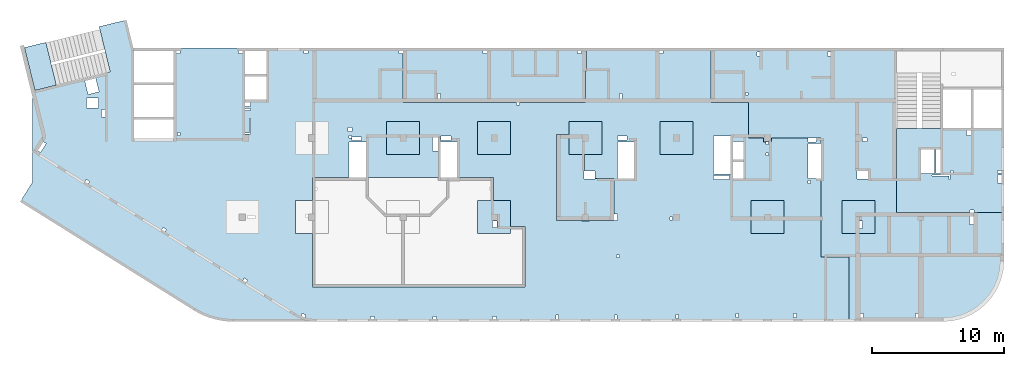
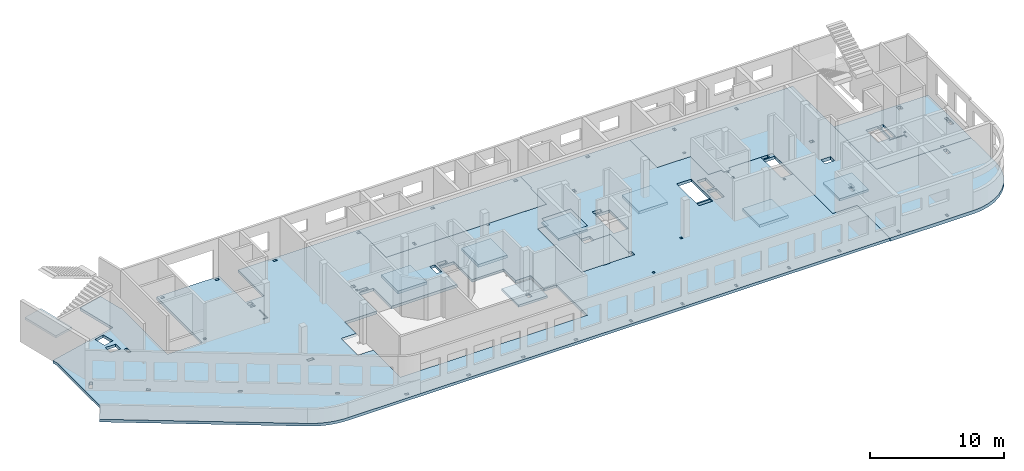
# One storey, part 2 of 10: 13 slabs.
"""IFC4 building model written with IfcOpenShell, lengths in millimetres."""

from ifc_helpers import new_model, entity, si_unit, converted_unit, derived_unit, direction, frame, origin, place, context, subcontext, project, spatial, indexed_curve, outline, extrude, material, type_object, element, save


model = new_model("IFC4")

# Units and contexts
model_context = context("Model", 3, precision=0.01, world=origin(), true_north=direction((6.12303176911189e-17, 1.0)))
plan_context = context("Plan", 3, precision=0.01, world=origin(), true_north=direction((6.12303176911189e-17, 1.0)))
body_context = subcontext(model_context, "Body", "Model", "MODEL_VIEW")
ifc_project = project(units=[si_unit("LENGTHUNIT", "METRE", prefix="MILLI"), si_unit("AREAUNIT", "SQUARE_METRE"), si_unit("VOLUMEUNIT", "CUBIC_METRE"), converted_unit("PLANEANGLEUNIT", "DEGREE", entity("IfcRatioMeasure", 0.0174532925199433), si_unit("PLANEANGLEUNIT", "RADIAN"), dimensions=[0, 0, 0, 0, 0, 0, 0]), si_unit("MASSUNIT", "GRAM", prefix="KILO"), derived_unit("MASSDENSITYUNIT", [(si_unit("MASSUNIT", "GRAM", prefix="KILO"), 1), (si_unit("LENGTHUNIT", "METRE"), -3)]), derived_unit("MOMENTOFINERTIAUNIT", [(si_unit("LENGTHUNIT", "METRE"), 4)]), si_unit("TIMEUNIT", "SECOND"), si_unit("FREQUENCYUNIT", "HERTZ"), si_unit("THERMODYNAMICTEMPERATUREUNIT", "DEGREE_CELSIUS"), derived_unit("THERMALTRANSMITTANCEUNIT", [(si_unit("MASSUNIT", "GRAM", prefix="KILO"), 1), (si_unit("THERMODYNAMICTEMPERATUREUNIT", "KELVIN"), -1), (si_unit("TIMEUNIT", "SECOND"), -3)]), derived_unit("VOLUMETRICFLOWRATEUNIT", [(si_unit("LENGTHUNIT", "METRE"), 3), (si_unit("TIMEUNIT", "SECOND"), -1)]), derived_unit("MASSFLOWRATEUNIT", [(si_unit("MASSUNIT", "GRAM", prefix="KILO"), 1), (si_unit("TIMEUNIT", "SECOND"), -1)]), derived_unit("ROTATIONALFREQUENCYUNIT", [(si_unit("TIMEUNIT", "SECOND"), -1)]), si_unit("ELECTRICCURRENTUNIT", "AMPERE"), si_unit("ELECTRICVOLTAGEUNIT", "VOLT"), si_unit("POWERUNIT", "WATT"), si_unit("FORCEUNIT", "NEWTON", prefix="KILO"), si_unit("ILLUMINANCEUNIT", "LUX"), si_unit("LUMINOUSFLUXUNIT", "LUMEN"), si_unit("LUMINOUSINTENSITYUNIT", "CANDELA"), derived_unit("USERDEFINED", [(si_unit("MASSUNIT", "GRAM", prefix="KILO"), -1), (si_unit("LENGTHUNIT", "METRE"), -2), (si_unit("TIMEUNIT", "SECOND"), 3), (si_unit("LUMINOUSFLUXUNIT", "LUMEN"), 1)]), derived_unit("LINEARVELOCITYUNIT", [(si_unit("LENGTHUNIT", "METRE"), 1), (si_unit("TIMEUNIT", "SECOND"), -1)]), si_unit("PRESSUREUNIT", "PASCAL"), derived_unit("USERDEFINED", [(si_unit("LENGTHUNIT", "METRE"), -2), (si_unit("MASSUNIT", "GRAM", prefix="KILO"), 1), (si_unit("TIMEUNIT", "SECOND"), -2)]), derived_unit("LINEARFORCEUNIT", [(si_unit("MASSUNIT", "GRAM", prefix="KILO"), 1), (si_unit("LENGTHUNIT", "METRE"), 1), (si_unit("TIMEUNIT", "SECOND"), -2), (si_unit("LENGTHUNIT", "METRE"), -1)]), derived_unit("PLANARFORCEUNIT", [(si_unit("MASSUNIT", "GRAM", prefix="KILO"), 1), (si_unit("LENGTHUNIT", "METRE"), 1), (si_unit("TIMEUNIT", "SECOND"), -2), (si_unit("LENGTHUNIT", "METRE"), -2)])], contexts=[model_context, plan_context])

# Site, building, storey
site_placement = place(None, origin())
site = spatial("IfcSite", under=ifc_project, at=site_placement, CompositionType="ELEMENT")
building_placement = place(site_placement, origin())
building = spatial("IfcBuilding", under=site, at=building_placement, CompositionType="ELEMENT")
storey_placement = place(building_placement, frame((0.0, 0.0, 4200.0)))
storey = spatial("IfcBuildingStorey", under=building, at=storey_placement, CompositionType="ELEMENT", Elevation=4200.0)

# Slabs
ifc_material = material()
slab_type_1 = type_object("IfcSlabType", PredefinedType="FLOOR", material=ifc_material)
slab_1_placement = place(storey_placement, origin())
element("IfcSlab", 1, at=slab_1_placement, inside=storey, type_object=slab_type_1, material=ifc_material, PredefinedType="FLOOR", context=body_context, shape_type="SweptSolid", body=[
    extrude(outline(indexed_curve([(-6148.863810471, 19959.387129888), (-6148.86381047096, 14559.387129888), (-2248.86381047095, 14559.387129888), (-2248.86381047095, 12934.387129888), (-6148.86381047096, 12934.387129888), (-6148.86381047092, 2589.38712988804), (-5948.86381047095, 2589.38712988804), (-5948.86381047095, 2889.3871298881), (-5748.86381047108, 2889.3871298881), (-5748.86381047108, 2589.38712988803), (-2048.86381047092, 2589.38712988804), (-2048.86381047089, -6010.61287011193), (-1848.86381047108, -6010.61287011193), (-1848.86381047108, -6210.61287011191), (-2048.86381047089, -6210.61287011191), (-2048.86381047088, -11210.612870112), (-4428.86381047078, -11210.612870112), (-4428.86381047078, -11310.612870112), (-6148.86381047087, -11310.612870112), (-6148.86381047084, -20730.6128701121), (-2048.86381047081, -20730.6128701119), (-2048.86381047066, -23560.6128701121), (651.136189529272, -23560.612870112), (651.136189529332, -24710.612870112), (951.136189529167, -24710.612870112), (951.136189529167, -24885.6128701119), (1151.13618952893, -24885.6128701119), (1151.13618952893, -25085.6128701119), (951.136189529167, -25085.6128701119), (951.136189529167, -25310.612870112), (651.13618952933, -25310.612870112), (651.136189529339, -28070.6128701119), (936.136189528923, -28070.6128701119), (936.136189528923, -28670.612870112), (651.136189529343, -28670.612870112), (651.136189529343, -29070.6128701119), (1056.13618952891, -29070.6128701119), (1056.13618952891, -28070.6128701119), (3726.13618952934, -28070.6128701119), (3726.13618952934, -29070.6128701119), (9651.13618952933, -29070.6128701119), (9651.13618952934, -31160.6128701119), (14551.1361895292, -31160.6128701119), (14551.1361895291, 15459.3871298881), (14542.4813688931, 15770.6090526414), (14516.5436590997, 16080.8689861379), (14473.4032338008, 16389.2079146363), (14413.1934403692, 16694.6727602364), (14336.1003877199, 16996.319328849), (14242.362371047, 17293.2152287074), (14132.2691352507, 17584.4427523971), (14006.1609793344, 17869.1017134961), (13864.4277045374, 18146.3122290575), (13707.5074094566, 18415.2174393349), (13700.2568944495, 18427.3871298935), (5483.13618952893, 31577.7857668567), (4013.36245521472, 30659.3871298881), (-2487.98081248951, 30659.387129888), (-2877.35012792884, 30754.3000199726), (-4338.56524356843, 24759.8315259752), (-7777.85952938926, 25598.1958951609), (-8282.29910745868, 23528.7900113196), (-6148.86381047102, 23008.7425863779), (-6148.86381047102, 22959.387129888), (701.136189528992, 22959.387129888), (701.136189529, 19959.387129888), (-6148.863810471, 19959.387129888)], self_intersect=False), holes=[indexed_curve([(5401.13618952907, 10739.3871298881), (6651.13618952907, 10739.3871298881), (7901.13618952907, 10739.3871298881), (7901.13618952906, 9439.38712988806), (11951.1361895291, 9439.38712988807), (11951.1361895292, -6635.6128701119), (7351.13618952919, -6635.61287011193), (7351.13618952918, -5560.61287011193), (6651.13618952918, -5560.61287011194), (5401.13618952913, -5560.61287011194), (5401.13618952912, -4310.61287011194), (5401.13618952912, -4260.61287011193), (3661.13618952913, -4260.61287011194), (3661.13618952912, -1510.61287011193), (951.13541588538, -1510.61287011193), (951.13541588538, -240.612870111946), (3661.13618952912, -240.612870111946), (3661.1361895291, 5409.38712988806), (951.13618952892, 5409.38712988806), (951.13618952892, 6669.38712988807), (3661.1361895291, 6669.38712988807), (3661.13618952909, 9439.38712988805), (5401.13618952906, 9439.38712988806), (5401.13618952907, 9489.38712988806), (5401.13618952907, 10739.3871298881)], self_intersect=False), indexed_curve([(401.136189529216, -9035.61287011196), (6651.1361895292, -9035.61287011194), (6901.1361895292, -9035.61287011194), (6901.1361895292, -10910.6128701119), (6951.1361895292, -10910.6128701119), (6951.1361895292, -11210.612870112), (6951.1361895292, -11510.612870112), (6901.1361895292, -11510.612870112), (6901.13618952895, -13385.612870112), (6901.13618952892, -13635.6128701119), (6401.13618952891, -13635.6128701119), (6401.13618952891, -13385.612870112), (3726.13618952915, -13385.612870112), (3726.13618952916, -11925.6128701119), (3166.13618952922, -11925.6128701119), (3166.13618952922, -11160.612870112), (1901.13618952915, -11160.612870112), (1901.13618952915, -12460.6128701119), (-598.863810470838, -12460.6128701119), (-598.863810470847, -9960.61287011195), (401.136189529218, -9960.61287011195), (401.136189529216, -9035.61287011196)], self_intersect=False), indexed_curve([(-2358.86381047109, 25649.3871298881), (-2358.86381047109, 26549.3871298881), (-1618.86381047108, 26549.3871298881), (-1618.86381047108, 25649.3871298881), (-2358.86381047109, 25649.3871298881)], self_intersect=False), indexed_curve([(-2845.01874476109, 25608.8640213711), (-3865.14975025251, 25857.5257884124), (-3663.85616990531, 26683.347133808), (-2643.72394620801, 26434.6903645437), (-2845.01874476109, 25608.8640213711)], self_intersect=False), indexed_curve([(1070.04881669485, 29610.0494864465), (937.569000669967, 29822.0615105065), (1616.01119569202, 30245.9909716361), (1748.48729366069, 30033.9848977099), (1070.04881669485, 29610.0494864465)], self_intersect=False), indexed_curve([(4124.42832046992, 26420.8069499175), (3954.6315026398, 26314.7081930707), (3795.65795471008, 26569.1240162138), (3965.4547725402, 26675.2227730606), (4124.42832046992, 26420.8069499175)], self_intersect=False), indexed_curve([(7754.32433139231, 20611.6456550412), (7584.52751356219, 20505.5468981944), (7425.55396563247, 20759.9627213374), (7595.35078346259, 20866.0614781842), (7754.32433139231, 20611.6456550412)], self_intersect=False), indexed_curve([(11594.4873180832, 14465.9802913018), (11424.690500253, 14359.881534455), (11265.7169523233, 14614.2973575981), (11435.5137701534, 14720.3961144449), (11594.4873180832, 14465.9802913018)], self_intersect=False), indexed_curve([(14046.0691106705, 9954.81624003096), (13949.2127758848, 10238.7508282936), (14137.123442309, 10302.851290757), (14233.9797770947, 10018.9167024943), (14046.0691106705, 9954.81624003096)], self_intersect=False), indexed_curve([(14151.1361895289, 4739.38712988809), (14151.1361895289, 5039.38712988809), (14351.1361895291, 5039.38712988809), (14351.1361895291, 4739.38712988809), (14151.1361895289, 4739.38712988809)], self_intersect=False), indexed_curve([(14151.1361895289, 339.387129888087), (14351.1361895289, 339.387129888087), (14351.1361895289, 39.3871298880856), (14151.1361895289, 39.3871298880856), (14151.1361895289, 339.387129888087)], self_intersect=False), indexed_curve([(14151.1361895289, -4470.61287011193), (14151.1361895289, -4170.61287011193), (14351.1361895292, -4170.61287011193), (14351.1361895292, -4470.61287011193), (14151.1361895289, -4470.61287011193)], self_intersect=False), indexed_curve([(14051.1361895289, -9185.61287011191), (14051.1361895289, -8985.61287011193), (14351.1361895292, -8985.61287011193), (14351.1361895292, -9185.61287011191), (14051.1361895289, -9185.61287011191)], self_intersect=False), indexed_curve([(14051.1361895289, -13610.6128701119), (14051.1361895289, -13410.6128701119), (14351.1361895289, -13410.6128701119), (14351.1361895289, -13610.6128701119), (14051.1361895289, -13610.6128701119)], self_intersect=False), indexed_curve([(14001.1361895289, -18260.6128701119), (14001.1361895289, -18060.6128701119), (14301.1361895289, -18060.6128701119), (14301.1361895289, -18260.6128701119), (14001.1361895289, -18260.6128701119)], self_intersect=False), indexed_curve([(13951.1361895289, -22810.6128701119), (13951.1361895289, -22610.6128701119), (14251.1361895289, -22610.6128701119), (14251.1361895289, -22810.6128701119), (13951.1361895289, -22810.6128701119)], self_intersect=False), indexed_curve([(13951.1361895289, -27185.6128701119), (13951.1361895289, -26985.6128701119), (14251.1361895289, -26985.6128701119), (14251.1361895289, -27185.6128701119), (13951.1361895289, -27185.6128701119)], self_intersect=False), indexed_curve([(4086.13618952892, -28070.6128701119), (4086.13618952892, -28270.6128701119), (3886.13618952891, -28270.6128701119), (3886.13618952891, -28070.6128701119), (4086.13618952892, -28070.6128701119)], self_intersect=False), indexed_curve([(-5948.86381047099, 15059.3871298881), (-5748.86381047108, 15059.3871298881), (-5748.86381047108, 14759.387129888), (-5948.86381047099, 14759.387129888), (-5948.86381047099, 15059.3871298881)], self_intersect=False), indexed_curve([(251.136189528923, 19459.3871298881), (251.136189528923, 19659.3871298881), (451.136189528912, 19659.3871298881), (451.136189528912, 19459.3871298881), (251.136189528923, 19459.3871298881)], self_intersect=False), indexed_curve([(-1748.86381047109, 14559.387129888), (-1748.86381047109, 14129.3871298881), (-2048.86381047076, 14129.3871298881), (-2048.86381047076, 14559.387129888), (-1748.86381047109, 14559.387129888)], self_intersect=False), indexed_curve([(-1438.86381047107, 14559.3871298881), (-1438.86381047107, 14129.3871298881), (-1596.25793295049, 14129.3871298881), (-1596.25793295049, 14559.3871298881), (-1438.86381047107, 14559.3871298881)], self_intersect=False), indexed_curve([(271.136189528919, 14549.3871298881), (351.136189529037, 14549.3871298881), (351.136189529039, 14159.387129888), (351.136189529039, 14129.3871298881), (-838.863810471089, 14129.3871298881), (-838.863810471089, 14209.3871298881), (271.136189528921, 14209.3871298881), (271.136189528919, 14549.3871298881)], self_intersect=False), indexed_curve([(6501.13618952892, 13809.3871298881), (6501.13618952892, 14369.3871298881), (6751.13618952892, 14369.3871298881), (6751.13618952892, 13809.3871298881), (6501.13618952892, 13809.3871298881)], self_intersect=False), indexed_curve([(-148.86381047109, 6439.38712988809), (-148.86381047109, 6739.38712988809), (151.136189528911, 6739.38712988809), (151.136189528911, 6439.38712988809), (-148.86381047109, 6439.38712988809)], self_intersect=False), indexed_curve([(451.136189528912, 6489.38712988807), (451.136189528912, 6689.3871298881), (651.136189529096, 6689.3871298881), (651.136189529096, 6489.38712988807), (451.136189528912, 6489.38712988807)], self_intersect=False), indexed_curve([(831.136189528913, 6449.38712988808), (831.136189528913, 5739.38712988807), (581.136189528917, 5739.38712988807), (581.136189528917, 6449.38712988808), (831.136189528913, 6449.38712988808)], self_intersect=False), indexed_curve([(601.136189529084, 369.387398442862), (1641.13618952892, 369.387398442862), (1641.13618952892, -90.6128701119455), (601.136189529084, -90.6128701119455), (601.136189529084, 369.387398442862)], self_intersect=False), indexed_curve([(511.135415885374, -1050.61287011191), (511.135415885374, -270.61260155714), (831.136189528913, -270.61260155714), (831.136189528913, -1050.61287011191), (511.135415885374, -1050.61287011191)], self_intersect=False), indexed_curve([(511.136189528916, -14370.6128701119), (511.136189528916, -13650.6128701119), (801.136189528919, -13650.6128701119), (801.136189528919, -14370.6128701119), (511.136189528916, -14370.6128701119)], self_intersect=False), indexed_curve([(951.13618952892, -14910.6128701119), (951.13618952892, -13650.6128701119), (3726.13618952925, -13650.6128701119), (3726.13618952925, -14910.6128701119), (951.13618952892, -14910.6128701119)], self_intersect=False), indexed_curve([(3796.13618952891, -22140.6128701119), (3496.13618952891, -22140.6128701119), (3496.13618952891, -20930.6128701119), (3796.13618952891, -20930.6128701119), (3796.13618952891, -22140.6128701119)], self_intersect=False), indexed_curve([(2476.13618952915, -23170.6128701119), (2476.13618952915, -22390.6128701119), (3726.13618952917, -22390.6128701119), (3726.13618952917, -23170.6128701119), (2476.13618952915, -23170.6128701119)], self_intersect=False), indexed_curve([(926.136189528926, -23170.6128701119), (926.136189528926, -22390.6128701119), (2276.13618952915, -22390.6128701119), (2276.13618952915, -23170.6128701119), (926.136189528926, -23170.6128701119)], self_intersect=False), indexed_curve([(3376.13618952892, -22190.6128701119), (516.136189528915, -22190.6128701119), (516.136189528915, -20930.6128701119), (3376.13618952892, -20930.6128701119), (3376.13618952892, -22190.6128701119)], self_intersect=False), indexed_curve([(1771.13618952892, -25085.6128701119), (1771.13618952892, -24885.6128701119), (1971.13618952891, -24885.6128701119), (1971.13618952891, -25085.6128701119), (1771.13618952892, -25085.6128701119)], self_intersect=False), indexed_curve([(6851.13618952891, -17810.6128701119), (6651.13618952926, -17810.6128701119), (6651.13618952926, -17610.6128701119), (6851.13618952891, -17610.6128701119), (6851.13618952891, -17810.6128701119)], self_intersect=False), indexed_curve([(-5948.86381047089, -17110.6128701119), (-5948.86381047089, -16810.6128701119), (-5748.86381047108, -16810.6128701119), (-5748.86381047108, -17110.6128701119), (-5948.86381047089, -17110.6128701119)], self_intersect=False), indexed_curve([(-5948.86381047109, 9789.38712988809), (-5948.86381047109, 10089.3871298881), (-5748.86381047108, 10089.3871298881), (-5748.86381047108, 9789.38712988809), (-5948.86381047109, 9789.38712988809)], self_intersect=False), indexed_curve([(-5948.86381047101, 19459.3871298881), (-5948.86381047101, 19759.387129888), (-5748.86381047108, 19759.387129888), (-5748.86381047108, 19459.3871298881), (-5948.86381047101, 19459.3871298881)], self_intersect=False), indexed_curve([(-938.863810471084, 25159.387129888), (-1498.86381047108, 25159.387129888), (-1498.86381047108, 25409.3871298881), (-938.863810471084, 25409.3871298881), (-938.863810471084, 25159.387129888)], self_intersect=False), indexed_curve([(-2708.86381047108, -13980.6128701119), (-2708.86381047108, -13780.6128701119), (-2348.86381047107, -13780.6128701119), (-2348.86381047107, -13980.6128701119), (-2708.86381047108, -13980.6128701119)], self_intersect=False), indexed_curve([(9701.13618952892, -13780.6128701119), (9501.13618952892, -13780.6128701119), (9501.13618952892, -13580.6128701119), (9701.13618952892, -13580.6128701119), (9701.13618952892, -13780.6128701119)], self_intersect=False)]), frame((30659.3873984427, 14351.1354158854, -400.0), z_axis=(0.0, 0.0, -1.0), x_axis=(0.0, -1.0, 0.0)), (0.0, 0.0, -1.0), 250.0),
])
slab_type_2 = type_object("IfcSlabType", PredefinedType="FLOOR", material=ifc_material)
slab_2_placement = place(storey_placement, origin())
element("IfcSlab", 2, at=slab_2_placement, inside=storey, type_object=slab_type_2, material=ifc_material, PredefinedType="FLOOR", context=body_context, shape_type="SweptSolid", body=[
    extrude(outline(indexed_curve([(-10063.7142857141, -4642.89201240349), (-10063.7142857141, -8742.89201240353), (3976.28571428571, -8742.89201240353), (3976.28571428572, 3707.10798759665), (12116.2857142857, 3707.10798759665), (12116.2857142857, 7357.10798759648), (12059.6520810234, 8076.70652678149), (11891.1456892434, 8778.58616172119), (11614.9157255522, 9445.46428639835), (11237.7638884105, 10060.9201481418), (10768.9769077439, 10609.7991810546), (10220.0978748311, 11078.5861617212), (9604.64201308768, 11455.7379988629), (8937.76388841052, 11731.9679625542), (8235.88425347083, 11900.4743543341), (7516.28571428577, 11957.1079875965), (366.285714285737, 11957.1079875965), (366.285714285731, 7057.10798759662), (-1723.71428571428, 7057.10798759662), (-1723.71428571429, -1942.89201240337), (-5483.71428571427, -1942.89201240337), (-5483.71428571427, -1642.89201240353), (-6083.71428571429, -1642.89201240353), (-6083.71428571429, -1942.89201240342), (-7233.71428571415, -1942.89201240342), (-7233.71428571415, -4642.89201240349), (-10063.7142857141, -4642.89201240349)], self_intersect=False), holes=[indexed_curve([(1466.28571428572, 11357.1079875962), (1266.28571428573, 11357.1079875962), (1266.28571428573, 11657.1079875956), (1466.28571428572, 11657.1079875956), (1466.28571428572, 11357.1079875962)], self_intersect=False), indexed_curve([(5616.28571428573, 11357.1079875962), (5416.28571428572, 11357.1079875962), (5416.28571428572, 11657.1079875965), (5616.28571428573, 11657.1079875965), (5616.28571428573, 11357.1079875962)], self_intersect=False), indexed_curve([(9821.28571428571, 4617.10798759617), (9821.28571428571, 4007.10798759665), (9521.28571428568, 4007.10798759665), (9521.28571428569, 4617.10798759617), (9821.28571428571, 4617.10798759617)], self_intersect=False), indexed_curve([(1001.28571428567, 572.107213952653), (1001.28571428567, 1172.1079875962), (1831.28571428573, 1172.1079875962), (1831.28571428572, 572.107213952651), (1001.28571428567, 572.107213952653)], self_intersect=False), indexed_curve([(1416.2857142857, -1692.89201240381), (1736.28571428565, -1692.89201240381), (1736.28571428565, -1942.89201240336), (1416.2857142857, -1942.89201240336), (1416.2857142857, -1692.89201240381)], self_intersect=False), indexed_curve([(-1033.71428571429, -8142.89201240379), (-1033.71428571429, -8442.89201240379), (-1233.71428571435, -8442.89201240379), (-1233.71428571435, -8142.89201240379), (-1033.71428571429, -8142.89201240379)], self_intersect=False), indexed_curve([(-6383.7142857143, -8142.89201240375), (-6383.7142857143, -8442.89201240376), (-6583.71428571435, -8442.89201240375), (-6583.71428571435, -8142.89201240375), (-6383.7142857143, -8142.89201240375)], self_intersect=False), indexed_curve([(-7463.71428571432, -5192.89201240378), (-7263.71428571432, -5192.89201240378), (-7263.71428571432, -5392.89201240377), (-7463.71428571432, -5392.89201240377), (-7463.71428571432, -5192.89201240378)], self_intersect=False), indexed_curve([(1166.28571428572, 4917.1079875962), (1416.28571428568, 4917.1079875962), (1416.28571428567, 4357.1079875962), (1166.28571428571, 4357.10798759621), (1166.28571428572, 4917.1079875962)], self_intersect=False)]), frame((61453.7145542689, 11757.1072139527, -450.0), z_axis=(0.0, 0.0, -1.0), x_axis=(1.0, 0.0, 0.0)), (0.0, 0.0, -1.0), 300.0),
])
slab_type_3 = type_object("IfcSlabType", PredefinedType="FLOOR", material=ifc_material)
slab_3_placement = place(storey_placement, origin())
element("IfcSlab", 3, at=slab_3_placement, inside=storey, type_object=slab_type_3, material=ifc_material, PredefinedType="FLOOR", context=body_context, shape_type="SweptSolid", body=[
    extrude(outline(indexed_curve([(-3734.28571428571, -3699.46019902423), (-3534.28571428573, -3699.46019902423), (1065.71428571429, -3699.46019902424), (1065.71428571429, -3659.46019902427), (4405.71428571427, -3659.46019902428), (4405.71428571427, -213.238805853918), (4405.71428571428, -13.2388058539183), (4405.71428571428, 2720.5398009757), (-1154.28571428569, 2720.53980097572), (-1154.28571428569, 2520.53980097523), (-1454.2857142857, 2520.53980097523), (-1454.2857142857, 2720.53980097572), (-3534.28571428572, 2720.53980097573), (-3734.28571428571, 2720.53980097573), (-3734.28571428571, -3699.46019902423)], self_intersect=False), holes=[indexed_curve([(-3534.28571428572, -114.460199024756), (-3534.28571428572, 485.539800975246), (-3234.28571428571, 485.539800975246), (-3234.28571428571, -114.460199024756), (-3534.28571428572, -114.460199024756)], self_intersect=False), indexed_curve([(-3534.28571428571, -479.460199024759), (-3534.28571428571, -279.460199024753), (-3234.28571428571, -279.460199024753), (-3234.28571428571, -479.460199024759), (-3534.28571428571, -479.460199024759)], self_intersect=False), indexed_curve([(-1234.28571428573, -3099.46019902475), (-884.285714285686, -3099.46019902475), (-884.285714285686, -3499.46019902425), (-1234.28571428573, -3499.46019902425), (-1234.28571428573, -3099.46019902475)], self_intersect=False), indexed_curve([(1395.71428571435, -2059.46019902427), (1065.71428571427, -2059.46019902427), (1065.71428571427, -254.460199024759), (1395.71428571435, -254.460199024759), (1395.71428571435, -2059.46019902427)], self_intersect=False), indexed_curve([(2555.71428571428, -254.460199024759), (2555.71428571428, -2059.46019902429), (1515.71428571432, -2059.46019902429), (1515.71428571432, -254.460199024759), (2555.71428571428, -254.460199024759)], self_intersect=False), indexed_curve([(115.714285714398, -464.460199024745), (115.714285714398, -314.460199024745), (265.714285714399, -314.460199024745), (265.714285714399, -464.460199024745), (115.714285714398, -464.460199024745)], self_intersect=False), indexed_curve([(435.714285714291, -54.4601990247521), (1735.71428571431, -54.4601990247564), (1735.71428571431, -114.460199024258), (355.714285714309, -114.460199024253), (355.714285714309, 205.539800975241), (435.714285714291, 205.539800975241), (435.714285714291, -54.4601990247521)], self_intersect=False)]), frame((69835.7145542689, 10770.5390273317, -400.0), z_axis=(0.0, 0.0, 1.0), x_axis=(-1.0, 0.0, 0.0)), (0.0, 0.0, 1.0), 250.0),
])
slab_type_4 = type_object("IfcSlabType", PredefinedType="FLOOR", material=ifc_material)
slab_4_placement = place(storey_placement, origin())
element("IfcSlab", 4, at=slab_4_placement, inside=storey, type_object=slab_type_4, material=ifc_material, PredefinedType="FLOOR", context=body_context, shape_type="SweptSolid", body=[
    extrude(outline(indexed_curve([(-1876.36363636365, -7881.81818181818), (-1676.36363636369, -7881.81818181818), (-1476.36363636382, -7881.81818181818), (2223.63636363634, -7881.81818181818), (2223.63636363637, 718.181818181788), (2223.63636363637, 918.181818181777), (2223.63636363639, 5918.18181818182), (-156.363636363512, 5918.18181818182), (-156.363636363512, 6018.18181818182), (-1676.36363636364, 6018.18181818182), (-1876.36363636361, 6018.18181818182), (-1876.36363636365, -7881.81818181818)], self_intersect=False), holes=[indexed_curve([(-1676.36363636367, -1831.81818181822), (-1676.36363636367, -1531.81818181818), (-1476.36363636382, -1531.81818181818), (-1476.36363636382, -1831.81818181822), (-1676.36363636367, -1831.81818181822)], self_intersect=False), indexed_curve([(-1676.36363636382, 5618.18181818178), (-1476.36363636382, 5618.18181818178), (-1476.36363636382, 5318.18181818178), (-1676.36363636382, 5318.18181818178), (-1676.36363636382, 5618.18181818178)], self_intersect=False), indexed_curve([(1563.63636363615, -5261.8181818182), (1563.63636363615, -5061.81818181821), (1923.63636363656, -5061.81818181821), (1923.63636363656, -5261.8181818182), (1563.63636363615, -5261.8181818182)], self_intersect=False)]), frame((35951.8184503728, 18623.6355899926, -450.0), z_axis=(0.0, 0.0, 1.0), x_axis=(0.0, -1.0, 0.0)), (0.0, 0.0, 1.0), 300.0),
])
slab_type_5 = type_object("IfcSlabType", PredefinedType="FLOOR", material=ifc_material)
slab_5_placement = place(storey_placement, origin())
element("IfcSlab", 5, at=slab_5_placement, inside=storey, type_object=slab_type_5, material=ifc_material, PredefinedType="FLOOR", context=body_context, shape_type="SweptSolid", body=[
    extrude(outline(indexed_curve([(-1250.0, -1250.0), (1250.0, -1250.0), (1250.0, 1250.0), (-1250.0, 1250.0), (-1250.0, -1250.0)], self_intersect=False), holes=[indexed_curve([(-199.999999999994, 299.999999999822), (-199.999999999994, 759.999999999822), (120.000000000007, 759.999999999822), (120.000000000007, 299.999999999822), (-199.999999999994, 299.999999999822)], self_intersect=False)]), frame((34970.0002685546, 7699.99922635628, -650.0), z_axis=(0.0, 0.0, 1.0), x_axis=(-1.0, 0.0, 0.0)), (0.0, 0.0, 1.0), 200.0),
])
slab_type_6 = type_object("IfcSlabType", PredefinedType="FLOOR", material=ifc_material)
slab_6_placement = place(storey_placement, origin())
element("IfcSlab", 6, at=slab_6_placement, inside=storey, type_object=slab_type_6, material=ifc_material, PredefinedType="FLOOR", context=body_context, shape_type="SweptSolid", body=[
    extrude(outline(indexed_curve([(-1250.0, -1250.0), (1250.0, -1250.0), (1250.0, 1250.0), (-1250.0, 1250.0), (-1250.0, -1250.0)], self_intersect=False)), frame((28070.0002685547, 13699.9992263563, -400.0), z_axis=(0.0, 0.0, -1.0), x_axis=(0.0, 1.0, 0.0)), (0.0, 0.0, 1.0), 250.0),
])
slab_type_7 = type_object("IfcSlabType", PredefinedType="FLOOR", material=ifc_material)
slab_7_placement = place(storey_placement, origin())
element("IfcSlab", 7, at=slab_7_placement, inside=storey, type_object=slab_type_7, material=ifc_material, PredefinedType="FLOOR", context=body_context, shape_type="SweptSolid", body=[
    extrude(outline(indexed_curve([(-1250.0, -1250.0), (1250.0, -1250.0), (1250.0, 1250.0), (-1250.0, 1250.0), (-1250.0, -1250.0)], self_intersect=False)), frame((34970.0002685546, 13699.9992263563, -400.0), z_axis=(0.0, 0.0, -1.0), x_axis=(0.0, 1.0, 0.0)), (0.0, 0.0, 1.0), 250.0),
])
slab_type_8 = type_object("IfcSlabType", PredefinedType="FLOOR", material=ifc_material)
slab_8_placement = place(storey_placement, origin())
element("IfcSlab", 8, at=slab_8_placement, inside=storey, type_object=slab_type_8, material=ifc_material, PredefinedType="FLOOR", context=body_context, shape_type="SweptSolid", body=[
    extrude(outline(indexed_curve([(-1250.0, -1250.0), (1250.0, -1250.0), (1250.0, 1250.0), (-1250.0, 1250.0), (-1250.0, -1250.0)], self_intersect=False)), frame((41870.0002685547, 13699.9992263562, -450.0), z_axis=(0.0, 0.0, -1.0), x_axis=(0.0, 1.0, 0.0)), (0.0, 0.0, 1.0), 200.0),
])
slab_type_9 = type_object("IfcSlabType", PredefinedType="FLOOR", material=ifc_material)
slab_9_placement = place(storey_placement, origin())
element("IfcSlab", 9, at=slab_9_placement, inside=storey, type_object=slab_type_9, material=ifc_material, PredefinedType="FLOOR", context=body_context, shape_type="SweptSolid", body=[
    extrude(outline(indexed_curve([(-3221.66666666668, -2238.88888888889), (3278.33333333331, -2238.88888888889), (3278.33333333331, -1313.8888888889), (4278.33333333337, -1313.8888888889), (4278.33333333337, 1186.1111111111), (1778.33333333338, 1186.1111111111), (1778.33333333338, -113.888888888894), (513.333333333305, -113.888888888893), (513.333333333305, -153.888888888892), (-86.6666666666948, -153.888888888891), (-86.6666666666959, 651.111111111108), (-46.666666666614, 651.111111111107), (-46.6666666666164, 2111.11111111116), (-3221.66666666668, 2111.11111111115), (-3221.66666666667, 236.111111111154), (-3271.66666666667, 236.111111111154), (-3271.66666666667, -363.8888888889), (-3221.66666666668, -363.8888888889), (-3221.66666666668, -2238.88888888889)], self_intersect=False)), frame((41933.8891574435, 10671.6658930229, -150.0), z_axis=(0.0, 0.0, -1.0), x_axis=(0.0, 1.0, 0.0)), (0.0, 0.0, 1.0), 300.0),
])
slab_type_10 = type_object("IfcSlabType", PredefinedType="FLOOR", material=ifc_material)
slab_10_placement = place(storey_placement, origin())
element("IfcSlab", 10, at=slab_10_placement, inside=storey, type_object=slab_type_10, material=ifc_material, PredefinedType="FLOOR", context=body_context, shape_type="SweptSolid", body=[
    extrude(outline(indexed_curve([(-1250.0, -1250.0), (1250.0, -1250.0), (1250.0, 1249.99999999999), (-1250.0, 1249.99999999999), (-1250.0, -1250.0)], self_intersect=False)), frame((48770.0002685547, 13699.9992263562, -400.0), z_axis=(0.0, 0.0, -1.0), x_axis=(0.0, 1.0, 0.0)), (0.0, 0.0, 1.0), 250.0),
])
slab_type_11 = type_object("IfcSlabType", PredefinedType="FLOOR", material=ifc_material)
slab_11_placement = place(storey_placement, origin())
element("IfcSlab", 11, at=slab_11_placement, inside=storey, type_object=slab_type_11, material=ifc_material, PredefinedType="FLOOR", context=body_context, shape_type="SweptSolid", body=[
    extrude(outline(indexed_curve([(-1250.0, -1249.99999999999), (1250.0, -1249.99999999999), (1250.0, 1250.0), (-1250.0, 1250.0), (-1250.0, -1249.99999999999)], self_intersect=False)), frame((55670.0002685546, 7699.99922635621, -400.0), z_axis=(0.0, 0.0, -1.0), x_axis=(0.0, 1.0, 0.0)), (0.0, 0.0, 1.0), 250.0),
])
slab_type_12 = type_object("IfcSlabType", PredefinedType="FLOOR", material=ifc_material)
slab_12_placement = place(storey_placement, origin())
element("IfcSlab", 12, at=slab_12_placement, inside=storey, type_object=slab_type_12, material=ifc_material, PredefinedType="FLOOR", context=body_context, shape_type="SweptSolid", body=[
    extrude(outline(indexed_curve([(-1250.00000000001, -1250.0), (1249.99999999999, -1250.0), (1249.99999999999, 1250.0), (-1250.00000000001, 1250.0), (-1250.00000000001, -1250.0)], self_intersect=False), holes=[indexed_curve([(-50.000000000006, 859.999999999729), (-50.000000000006, 299.999999999735), (-299.999999999966, 299.999999999735), (-299.999999999966, 859.999999999729), (-50.000000000006, 859.999999999729)], self_intersect=False)]), frame((62570.0002685546, 7699.99922635619, -650.0), z_axis=(0.0, 0.0, 1.0), x_axis=(-1.0, 0.0, 0.0)), (0.0, 0.0, 1.0), 200.0),
])
slab_type_13 = type_object("IfcSlabType", PredefinedType="FLOOR", material=ifc_material)
slab_13_placement = place(storey_placement, origin())
element("IfcSlab", 13, at=slab_13_placement, inside=storey, type_object=slab_type_13, material=ifc_material, PredefinedType="FLOOR", context=body_context, shape_type="SweptSolid", body=[
    extrude(outline(indexed_curve([(-835.0, -1670.00000000002), (835.0, -1670.00000000002), (835.0, 1670.00000000002), (-835.000000000001, 1670.00000000002), (-835.0, -1670.00000000002)], self_intersect=False)), frame((612.299389166834, 19119.7750964545, 1920.0), z_axis=(0.0, 0.0, -1.0), x_axis=(0.971552058141474, 0.236826092990333, 0.0)), (0.0, 0.0, 1.0), 200.0),
])

save(model, "model.ifc")
